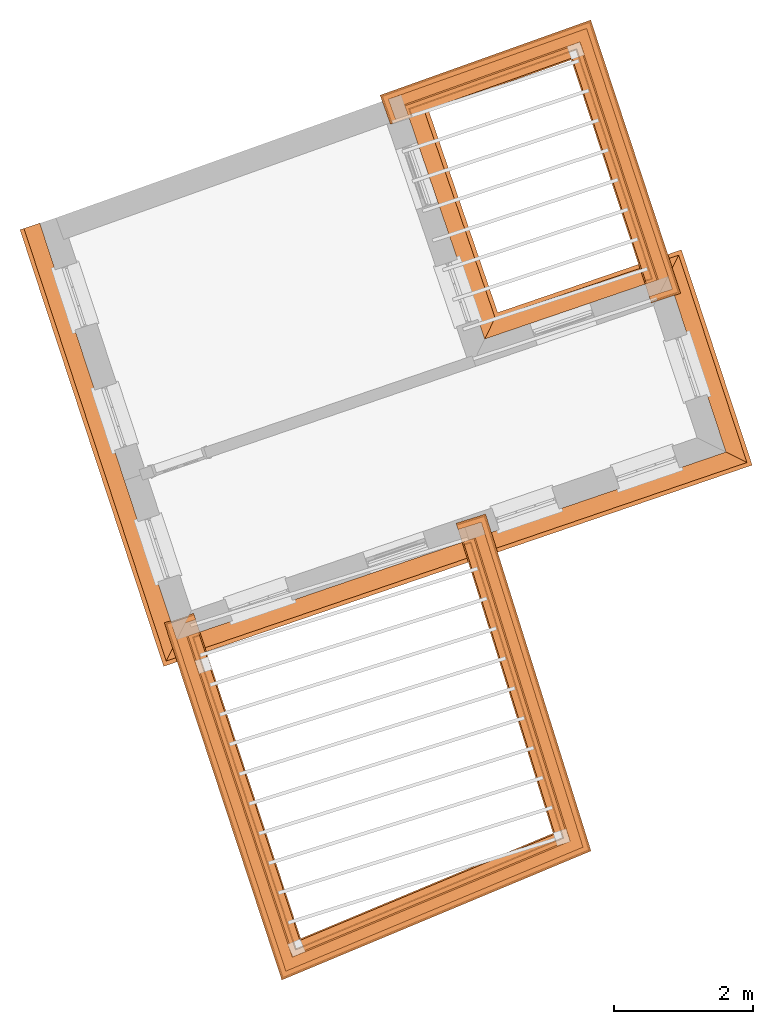
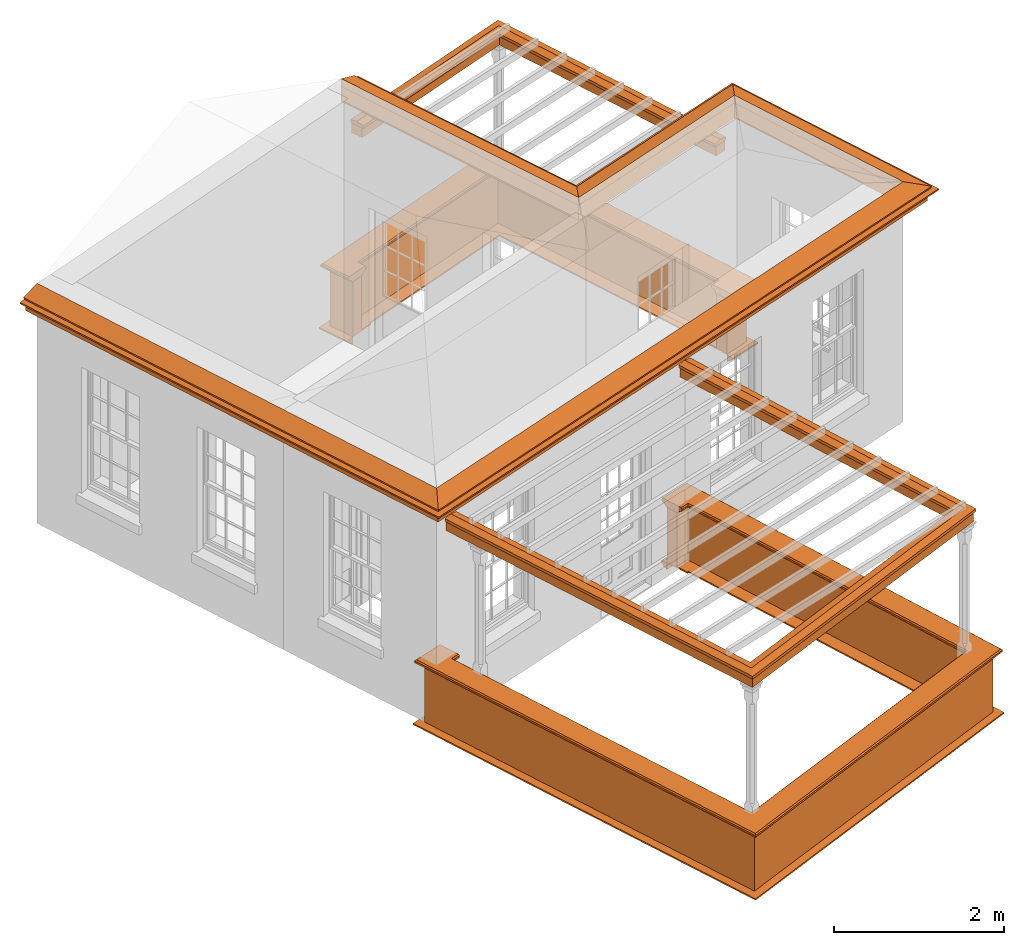
# One storey, part 9 of 10: 12 proxies.
"""IFC2X3 building model written with IfcOpenShell, lengths in metres."""

from ifc_helpers import new_model, entity, si_unit, frame, origin, place, context, subcontext, project, spatial, element, save


model = new_model("IFC2X3")

# Units and contexts
model_context = context("Model", 3, world=origin())
body_context = subcontext(model_context, "Body", "Model", "MODEL_VIEW")
ifc_project = project(units=[si_unit("PLANEANGLEUNIT", "RADIAN"), si_unit("MASSUNIT", "GRAM", prefix="KILO"), si_unit("FORCEUNIT", "NEWTON", prefix="KILO"), si_unit("LENGTHUNIT", "METRE")], contexts=[model_context])

# Site, building, storey
site_placement = place(None, origin())
site = spatial("IfcSite", under=ifc_project, at=site_placement, CompositionType="ELEMENT")
building_placement = place(None, origin())
building = spatial("IfcBuilding", under=site, at=building_placement, Name="Building plot-2", CompositionType="ELEMENT")
storey_placement = place(None, frame((0.0, 0.0, 8.2)))
storey = spatial("IfcBuildingStorey", under=building, at=storey_placement, Name="Floor 2", CompositionType="ELEMENT", Elevation=8.2)

# Proxies
proxy_1_placement = place(storey_placement, frame((0.0, 0.0, 3.45)))
axis2_placement3_d_1 = entity("IfcAxis2Placement3D", entity("IfcCartesianPoint", [0.0, 0.0, 0.0]))
element("IfcBuildingElementProxy", 1, at=proxy_1_placement, inside=storey, Name="eaves", CompositionType="ELEMENT", context=body_context, shape_type="SweptSolid", held_by="IfcProductRepresentation", body=[
    entity("IfcSurfaceCurveSweptAreaSolid", entity("IfcArbitraryClosedProfileDef", "AREA", None, entity("IfcPolyline", [entity("IfcCartesianPoint", [-0.11, 0.25]), entity("IfcCartesianPoint", [-0.33, 0.25]), entity("IfcCartesianPoint", [-0.33, 0.265]), entity("IfcCartesianPoint", [-0.318, 0.268]), entity("IfcCartesianPoint", [-0.309, 0.274]), entity("IfcCartesianPoint", [-0.303, 0.283]), entity("IfcCartesianPoint", [-0.3, 0.295]), entity("IfcCartesianPoint", [-0.285, 0.295]), entity("IfcCartesianPoint", [-0.285, 0.455]), entity("IfcCartesianPoint", [-0.205, 0.455]), entity("IfcCartesianPoint", [-0.205, 0.47]), entity("IfcCartesianPoint", [-0.19, 0.47]), entity("IfcCartesianPoint", [-0.189, 0.483]), entity("IfcCartesianPoint", [-0.186, 0.494]), entity("IfcCartesianPoint", [-0.179, 0.506]), entity("IfcCartesianPoint", [-0.17, 0.514]), entity("IfcCartesianPoint", [-0.16, 0.52]), entity("IfcCartesianPoint", [-0.149, 0.529]), entity("IfcCartesianPoint", [-0.143, 0.539]), entity("IfcCartesianPoint", [-0.14, 0.55]), entity("IfcCartesianPoint", [-0.12, 0.55]), entity("IfcCartesianPoint", [-0.11, 0.48]), entity("IfcCartesianPoint", [-0.11, 0.25])])), axis2_placement3_d_1, entity("IfcPolyline", [entity("IfcCartesianPoint", [27.4733871491026, 37.075639312766]), entity("IfcCartesianPoint", [29.3656234063289, 31.3238094691099]), entity("IfcCartesianPoint", [36.7900182467318, 33.8623867786949]), entity("IfcCartesianPoint", [36.1147616833761, 35.9149639018745]), entity("IfcCartesianPoint", [33.4792220942779, 35.0138101858856]), entity("IfcCartesianPoint", [32.1975835888228, 38.7621263278582])]), 0.0, 1.0, entity("IfcPlane", axis2_placement3_d_1)),
])
proxy_2_placement = place(storey_placement, frame((0.0, 0.0, 3.45)))
axis2_placement3_d_2 = entity("IfcAxis2Placement3D", entity("IfcCartesianPoint", [0.0, 0.0, 0.0]))
element("IfcBuildingElementProxy", 2, at=proxy_2_placement, inside=storey, Name="eaves", CompositionType="ELEMENT", context=body_context, shape_type="SweptSolid", held_by="IfcProductRepresentation", body=[
    entity("IfcSurfaceCurveSweptAreaSolid", entity("IfcArbitraryClosedProfileDef", "AREA", None, entity("IfcPolyline", [entity("IfcCartesianPoint", [-0.11, 0.25]), entity("IfcCartesianPoint", [-0.11, 0.48]), entity("IfcCartesianPoint", [-0.08, 0.49]), entity("IfcCartesianPoint", [0.0, 0.25]), entity("IfcCartesianPoint", [-0.11, 0.25])])), axis2_placement3_d_2, entity("IfcPolyline", [entity("IfcCartesianPoint", [27.4733871491026, 37.075639312766]), entity("IfcCartesianPoint", [29.3656234063289, 31.3238094691099]), entity("IfcCartesianPoint", [36.7900182467318, 33.8623867786949]), entity("IfcCartesianPoint", [36.1147616833761, 35.9149639018745]), entity("IfcCartesianPoint", [33.4792220942779, 35.0138101858856]), entity("IfcCartesianPoint", [32.1975835888228, 38.7621263278582])]), 0.0, 1.0, entity("IfcPlane", axis2_placement3_d_2)),
])
proxy_3_placement = place(storey_placement, origin())
axis2_placement3_d_3 = entity("IfcAxis2Placement3D", entity("IfcCartesianPoint", [0.0, 0.0, 0.0]))
element("IfcBuildingElementProxy", 3, at=proxy_3_placement, inside=storey, Name="parapet", CompositionType="ELEMENT", context=body_context, shape_type="SweptSolid", held_by="IfcProductRepresentation", body=[
    entity("IfcSurfaceCurveSweptAreaSolid", entity("IfcArbitraryClosedProfileDef", "AREA", None, entity("IfcPolyline", [entity("IfcCartesianPoint", [0.0, 0.25]), entity("IfcCartesianPoint", [0.795, 0.25]), entity("IfcCartesianPoint", [0.795, 0.09]), entity("IfcCartesianPoint", [0.02, 0.09]), entity("IfcCartesianPoint", [0.02, -0.08]), entity("IfcCartesianPoint", [0.0, -0.08]), entity("IfcCartesianPoint", [0.0, 0.25])])), axis2_placement3_d_3, entity("IfcPolyline", [entity("IfcCartesianPoint", [29.5574911386609, 31.0605856607457]), entity("IfcCartesianPoint", [29.4624994762423, 31.0293353156123]), entity("IfcCartesianPoint", [30.9280592094509, 26.5744739424948]), entity("IfcCartesianPoint", [34.7416099113103, 28.1657141668522]), entity("IfcCartesianPoint", [33.4220440068238, 32.3832884193432]), entity("IfcCartesianPoint", [33.3266061544124, 32.3534284741472])]), 0.0, 1.0, entity("IfcPlane", axis2_placement3_d_3)),
])
proxy_4_placement = place(storey_placement, origin())
axis2_placement3_d_4 = entity("IfcAxis2Placement3D", entity("IfcCartesianPoint", [0.0, 0.0, 0.0]))
element("IfcBuildingElementProxy", 4, at=proxy_4_placement, inside=storey, Name="parapet", CompositionType="ELEMENT", context=body_context, shape_type="SweptSolid", held_by="IfcProductRepresentation", body=[
    entity("IfcSurfaceCurveSweptAreaSolid", entity("IfcArbitraryClosedProfileDef", "AREA", None, entity("IfcPolyline", [entity("IfcCartesianPoint", [0.795, 0.265]), entity("IfcCartesianPoint", [0.807, 0.268]), entity("IfcCartesianPoint", [0.816, 0.274]), entity("IfcCartesianPoint", [0.822, 0.283]), entity("IfcCartesianPoint", [0.825, 0.295]), entity("IfcCartesianPoint", [0.84, 0.295]), entity("IfcCartesianPoint", [0.84, 0.305]), entity("IfcCartesianPoint", [0.842, 0.317]), entity("IfcCartesianPoint", [0.849, 0.326]), entity("IfcCartesianPoint", [0.858, 0.333]), entity("IfcCartesianPoint", [0.87, 0.335]), entity("IfcCartesianPoint", [0.882, 0.333]), entity("IfcCartesianPoint", [0.891, 0.326]), entity("IfcCartesianPoint", [0.898, 0.317]), entity("IfcCartesianPoint", [0.9, 0.305]), entity("IfcCartesianPoint", [0.9, 0.035]), entity("IfcCartesianPoint", [0.898, 0.023]), entity("IfcCartesianPoint", [0.891, 0.014]), entity("IfcCartesianPoint", [0.882, 0.007]), entity("IfcCartesianPoint", [0.87, 0.005]), entity("IfcCartesianPoint", [0.858, 0.007]), entity("IfcCartesianPoint", [0.849, 0.014]), entity("IfcCartesianPoint", [0.842, 0.023]), entity("IfcCartesianPoint", [0.84, 0.035]), entity("IfcCartesianPoint", [0.84, 0.045]), entity("IfcCartesianPoint", [0.825, 0.045]), entity("IfcCartesianPoint", [0.822, 0.057]), entity("IfcCartesianPoint", [0.816, 0.066]), entity("IfcCartesianPoint", [0.807, 0.072]), entity("IfcCartesianPoint", [0.795, 0.075]), entity("IfcCartesianPoint", [0.795, 0.265])])), axis2_placement3_d_4, entity("IfcPolyline", [entity("IfcCartesianPoint", [29.5574911386609, 31.0605856607457]), entity("IfcCartesianPoint", [29.4624994762423, 31.0293353156123]), entity("IfcCartesianPoint", [30.9280592094509, 26.5744739424948]), entity("IfcCartesianPoint", [34.7416099113103, 28.1657141668522]), entity("IfcCartesianPoint", [33.4220440068238, 32.3832884193432]), entity("IfcCartesianPoint", [33.3266061544124, 32.3534284741472])]), 0.0, 1.0, entity("IfcPlane", axis2_placement3_d_4)),
])
proxy_5_placement = place(storey_placement, origin())
axis2_placement3_d_5 = entity("IfcAxis2Placement3D", entity("IfcCartesianPoint", [0.0, 0.0, 0.0]))
element("IfcBuildingElementProxy", 5, at=proxy_5_placement, inside=storey, Name="parapet", CompositionType="ELEMENT", context=body_context, shape_type="SweptSolid", held_by="IfcProductRepresentation", body=[
    entity("IfcSurfaceCurveSweptAreaSolid", entity("IfcArbitraryClosedProfileDef", "AREA", None, entity("IfcPolyline", [entity("IfcCartesianPoint", [-0.1, 0.25]), entity("IfcCartesianPoint", [-0.1, 0.265]), entity("IfcCartesianPoint", [-0.085, 0.265]), entity("IfcCartesianPoint", [-0.084, 0.278]), entity("IfcCartesianPoint", [-0.081, 0.289]), entity("IfcCartesianPoint", [-0.074, 0.301]), entity("IfcCartesianPoint", [-0.065, 0.309]), entity("IfcCartesianPoint", [-0.055, 0.315]), entity("IfcCartesianPoint", [-0.044, 0.324]), entity("IfcCartesianPoint", [-0.038, 0.334]), entity("IfcCartesianPoint", [-0.035, 0.345]), entity("IfcCartesianPoint", [-0.015, 0.345]), entity("IfcCartesianPoint", [0.0, 0.25]), entity("IfcCartesianPoint", [-0.1, 0.25])])), axis2_placement3_d_5, entity("IfcPolyline", [entity("IfcCartesianPoint", [29.5574911386609, 31.0605856607457]), entity("IfcCartesianPoint", [29.4624994762423, 31.0293353156123]), entity("IfcCartesianPoint", [30.9280592094509, 26.5744739424948]), entity("IfcCartesianPoint", [34.7416099113103, 28.1657141668522]), entity("IfcCartesianPoint", [33.4220440068238, 32.3832884193432]), entity("IfcCartesianPoint", [33.3266061544124, 32.3534284741472])]), 0.0, 1.0, entity("IfcPlane", axis2_placement3_d_5)),
])
proxy_6_placement = place(storey_placement, origin())
axis2_placement3_d_6 = entity("IfcAxis2Placement3D", entity("IfcCartesianPoint", [0.0, 0.0, 0.0]))
element("IfcBuildingElementProxy", 6, at=proxy_6_placement, inside=storey, Name="parapet", CompositionType="ELEMENT", context=body_context, shape_type="SweptSolid", held_by="IfcProductRepresentation", body=[
    entity("IfcSurfaceCurveSweptAreaSolid", entity("IfcArbitraryClosedProfileDef", "AREA", None, entity("IfcPolyline", [entity("IfcCartesianPoint", [0.0, 0.25]), entity("IfcCartesianPoint", [0.795, 0.25]), entity("IfcCartesianPoint", [0.795, 0.09]), entity("IfcCartesianPoint", [0.02, 0.09]), entity("IfcCartesianPoint", [0.02, -0.08]), entity("IfcCartesianPoint", [0.0, -0.08]), entity("IfcCartesianPoint", [0.0, 0.25])])), axis2_placement3_d_6, entity("IfcPolyline", [entity("IfcCartesianPoint", [35.9228939510441, 36.1781877102387]), entity("IfcCartesianPoint", [36.0178856134627, 36.2094380553721]), entity("IfcCartesianPoint", [34.9430056935765, 39.4767501459936]), entity("IfcCartesianPoint", [32.5704224427225, 38.6297934237104]), entity("IfcCartesianPoint", [32.6040421960727, 38.5356142742946])]), 0.0, 1.0, entity("IfcPlane", axis2_placement3_d_6)),
])
proxy_7_placement = place(storey_placement, origin())
axis2_placement3_d_7 = entity("IfcAxis2Placement3D", entity("IfcCartesianPoint", [0.0, 0.0, 0.0]))
element("IfcBuildingElementProxy", 7, at=proxy_7_placement, inside=storey, Name="parapet", CompositionType="ELEMENT", context=body_context, shape_type="SweptSolid", held_by="IfcProductRepresentation", body=[
    entity("IfcSurfaceCurveSweptAreaSolid", entity("IfcArbitraryClosedProfileDef", "AREA", None, entity("IfcPolyline", [entity("IfcCartesianPoint", [0.795, 0.265]), entity("IfcCartesianPoint", [0.807, 0.268]), entity("IfcCartesianPoint", [0.816, 0.274]), entity("IfcCartesianPoint", [0.822, 0.283]), entity("IfcCartesianPoint", [0.825, 0.295]), entity("IfcCartesianPoint", [0.84, 0.295]), entity("IfcCartesianPoint", [0.84, 0.305]), entity("IfcCartesianPoint", [0.842, 0.317]), entity("IfcCartesianPoint", [0.849, 0.326]), entity("IfcCartesianPoint", [0.858, 0.333]), entity("IfcCartesianPoint", [0.87, 0.335]), entity("IfcCartesianPoint", [0.882, 0.333]), entity("IfcCartesianPoint", [0.891, 0.326]), entity("IfcCartesianPoint", [0.898, 0.317]), entity("IfcCartesianPoint", [0.9, 0.305]), entity("IfcCartesianPoint", [0.9, 0.035]), entity("IfcCartesianPoint", [0.898, 0.023]), entity("IfcCartesianPoint", [0.891, 0.014]), entity("IfcCartesianPoint", [0.882, 0.007]), entity("IfcCartesianPoint", [0.87, 0.005]), entity("IfcCartesianPoint", [0.858, 0.007]), entity("IfcCartesianPoint", [0.849, 0.014]), entity("IfcCartesianPoint", [0.842, 0.023]), entity("IfcCartesianPoint", [0.84, 0.035]), entity("IfcCartesianPoint", [0.84, 0.045]), entity("IfcCartesianPoint", [0.825, 0.045]), entity("IfcCartesianPoint", [0.822, 0.057]), entity("IfcCartesianPoint", [0.816, 0.066]), entity("IfcCartesianPoint", [0.807, 0.072]), entity("IfcCartesianPoint", [0.795, 0.075]), entity("IfcCartesianPoint", [0.795, 0.265])])), axis2_placement3_d_7, entity("IfcPolyline", [entity("IfcCartesianPoint", [35.9228939510441, 36.1781877102387]), entity("IfcCartesianPoint", [36.0178856134627, 36.2094380553721]), entity("IfcCartesianPoint", [34.9430056935765, 39.4767501459936]), entity("IfcCartesianPoint", [32.5704224427225, 38.6297934237104]), entity("IfcCartesianPoint", [32.6040421960727, 38.5356142742946])]), 0.0, 1.0, entity("IfcPlane", axis2_placement3_d_7)),
])
proxy_8_placement = place(storey_placement, origin())
axis2_placement3_d_8 = entity("IfcAxis2Placement3D", entity("IfcCartesianPoint", [0.0, 0.0, 0.0]))
element("IfcBuildingElementProxy", 8, at=proxy_8_placement, inside=storey, Name="parapet", CompositionType="ELEMENT", context=body_context, shape_type="SweptSolid", held_by="IfcProductRepresentation", body=[
    entity("IfcSurfaceCurveSweptAreaSolid", entity("IfcArbitraryClosedProfileDef", "AREA", None, entity("IfcPolyline", [entity("IfcCartesianPoint", [-0.1, 0.25]), entity("IfcCartesianPoint", [-0.1, 0.265]), entity("IfcCartesianPoint", [-0.085, 0.265]), entity("IfcCartesianPoint", [-0.084, 0.278]), entity("IfcCartesianPoint", [-0.081, 0.289]), entity("IfcCartesianPoint", [-0.074, 0.301]), entity("IfcCartesianPoint", [-0.065, 0.309]), entity("IfcCartesianPoint", [-0.055, 0.315]), entity("IfcCartesianPoint", [-0.044, 0.324]), entity("IfcCartesianPoint", [-0.038, 0.334]), entity("IfcCartesianPoint", [-0.035, 0.345]), entity("IfcCartesianPoint", [-0.015, 0.345]), entity("IfcCartesianPoint", [0.0, 0.25]), entity("IfcCartesianPoint", [-0.1, 0.25])])), axis2_placement3_d_8, entity("IfcPolyline", [entity("IfcCartesianPoint", [35.9228939510441, 36.1781877102387]), entity("IfcCartesianPoint", [36.0178856134627, 36.2094380553721]), entity("IfcCartesianPoint", [34.9430056935765, 39.4767501459936]), entity("IfcCartesianPoint", [32.5704224427225, 38.6297934237104]), entity("IfcCartesianPoint", [32.6040421960727, 38.5356142742946])]), 0.0, 1.0, entity("IfcPlane", axis2_placement3_d_8)),
])
proxy_9_placement = place(storey_placement, frame((0.0, 0.0, 3.45)))
axis2_placement3_d_9 = entity("IfcAxis2Placement3D", entity("IfcCartesianPoint", [0.0, 0.0, 0.0]))
element("IfcBuildingElementProxy", 9, at=proxy_9_placement, inside=storey, Name="pergola beam", CompositionType="ELEMENT", context=body_context, shape_type="SweptSolid", held_by="IfcProductRepresentation", body=[
    entity("IfcSurfaceCurveSweptAreaSolid", entity("IfcArbitraryClosedProfileDef", "AREA", None, entity("IfcPolyline", [entity("IfcCartesianPoint", [-0.7, -0.08]), entity("IfcCartesianPoint", [-0.7, 0.08]), entity("IfcCartesianPoint", [-0.56, 0.08]), entity("IfcCartesianPoint", [-0.56, -0.08]), entity("IfcCartesianPoint", [-0.7, -0.08])])), axis2_placement3_d_9, entity("IfcPolyline", [entity("IfcCartesianPoint", [36.0366358205427, 36.152443057921]), entity("IfcCartesianPoint", [34.9430056935765, 39.4767501459936]), entity("IfcCartesianPoint", [32.513914953073, 38.6096215717002])]), 0.0, 1.0, entity("IfcPlane", axis2_placement3_d_9)),
])
proxy_10_placement = place(storey_placement, frame((0.0, 0.0, 3.45)))
axis2_placement3_d_10 = entity("IfcAxis2Placement3D", entity("IfcCartesianPoint", [0.0, 0.0, 0.0]))
element("IfcBuildingElementProxy", 10, at=proxy_10_placement, inside=storey, Name="pergola beam", CompositionType="ELEMENT", context=body_context, shape_type="SweptSolid", held_by="IfcProductRepresentation", body=[
    entity("IfcSurfaceCurveSweptAreaSolid", entity("IfcArbitraryClosedProfileDef", "AREA", None, entity("IfcPolyline", [entity("IfcCartesianPoint", [-0.5, 0.0]), entity("IfcCartesianPoint", [-0.52, -0.1]), entity("IfcCartesianPoint", [-0.56, -0.1]), entity("IfcCartesianPoint", [-0.56, 0.1]), entity("IfcCartesianPoint", [-0.52, 0.1]), entity("IfcCartesianPoint", [-0.5, 0.0])])), axis2_placement3_d_10, entity("IfcPolyline", [entity("IfcCartesianPoint", [36.0366358205427, 36.152443057921]), entity("IfcCartesianPoint", [34.9430056935765, 39.4767501459936]), entity("IfcCartesianPoint", [32.513914953073, 38.6096215717002])]), 0.0, 1.0, entity("IfcPlane", axis2_placement3_d_10)),
])
proxy_11_placement = place(storey_placement, frame((0.0, 0.0, 3.45)))
axis2_placement3_d_11 = entity("IfcAxis2Placement3D", entity("IfcCartesianPoint", [0.0, 0.0, 0.0]))
element("IfcBuildingElementProxy", 11, at=proxy_11_placement, inside=storey, Name="pergola beam", CompositionType="ELEMENT", context=body_context, shape_type="SweptSolid", held_by="IfcProductRepresentation", body=[
    entity("IfcSurfaceCurveSweptAreaSolid", entity("IfcArbitraryClosedProfileDef", "AREA", None, entity("IfcPolyline", [entity("IfcCartesianPoint", [-0.7, -0.08]), entity("IfcCartesianPoint", [-0.7, 0.08]), entity("IfcCartesianPoint", [-0.56, 0.08]), entity("IfcCartesianPoint", [-0.56, -0.08]), entity("IfcCartesianPoint", [-0.7, -0.08])])), axis2_placement3_d_11, entity("IfcPolyline", [entity("IfcCartesianPoint", [29.4437492691623, 31.0863303130634]), entity("IfcCartesianPoint", [30.9280592094509, 26.5744739424948]), entity("IfcCartesianPoint", [34.7416099113103, 28.1657141668522]), entity("IfcCartesianPoint", [33.4041280397062, 32.44055113079])]), 0.0, 1.0, entity("IfcPlane", axis2_placement3_d_11)),
])
proxy_12_placement = place(storey_placement, frame((0.0, 0.0, 3.45)))
axis2_placement3_d_12 = entity("IfcAxis2Placement3D", entity("IfcCartesianPoint", [0.0, 0.0, 0.0]))
element("IfcBuildingElementProxy", 12, at=proxy_12_placement, inside=storey, Name="pergola beam", CompositionType="ELEMENT", context=body_context, shape_type="SweptSolid", held_by="IfcProductRepresentation", body=[
    entity("IfcSurfaceCurveSweptAreaSolid", entity("IfcArbitraryClosedProfileDef", "AREA", None, entity("IfcPolyline", [entity("IfcCartesianPoint", [-0.5, 0.0]), entity("IfcCartesianPoint", [-0.52, -0.1]), entity("IfcCartesianPoint", [-0.56, -0.1]), entity("IfcCartesianPoint", [-0.56, 0.1]), entity("IfcCartesianPoint", [-0.52, 0.1]), entity("IfcCartesianPoint", [-0.5, 0.0])])), axis2_placement3_d_12, entity("IfcPolyline", [entity("IfcCartesianPoint", [29.4437492691623, 31.0863303130634]), entity("IfcCartesianPoint", [30.9280592094509, 26.5744739424948]), entity("IfcCartesianPoint", [34.7416099113103, 28.1657141668522]), entity("IfcCartesianPoint", [33.4041280397062, 32.44055113079])]), 0.0, 1.0, entity("IfcPlane", axis2_placement3_d_12)),
])

save(model, "model.ifc")
